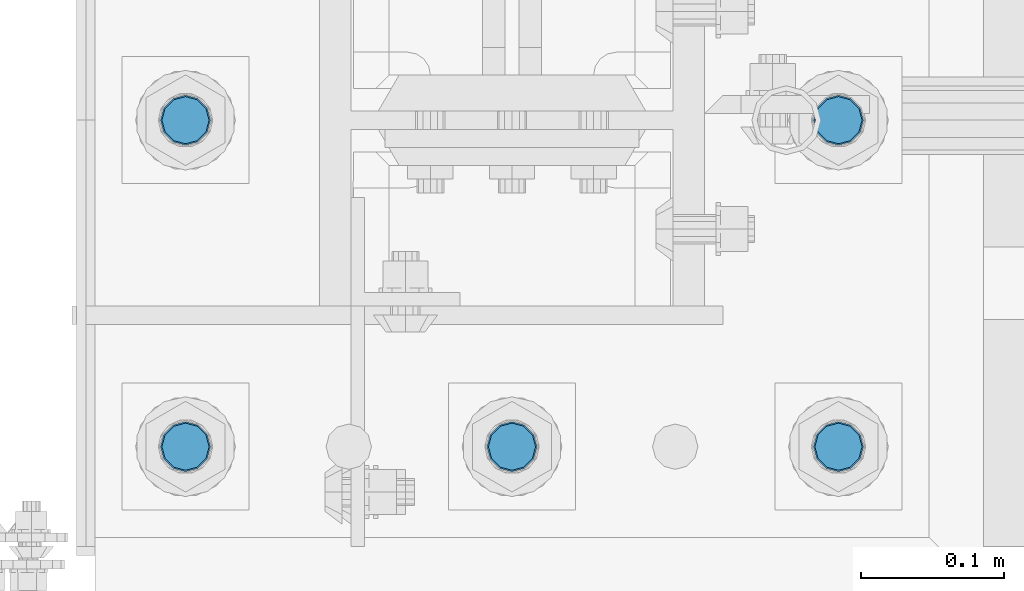
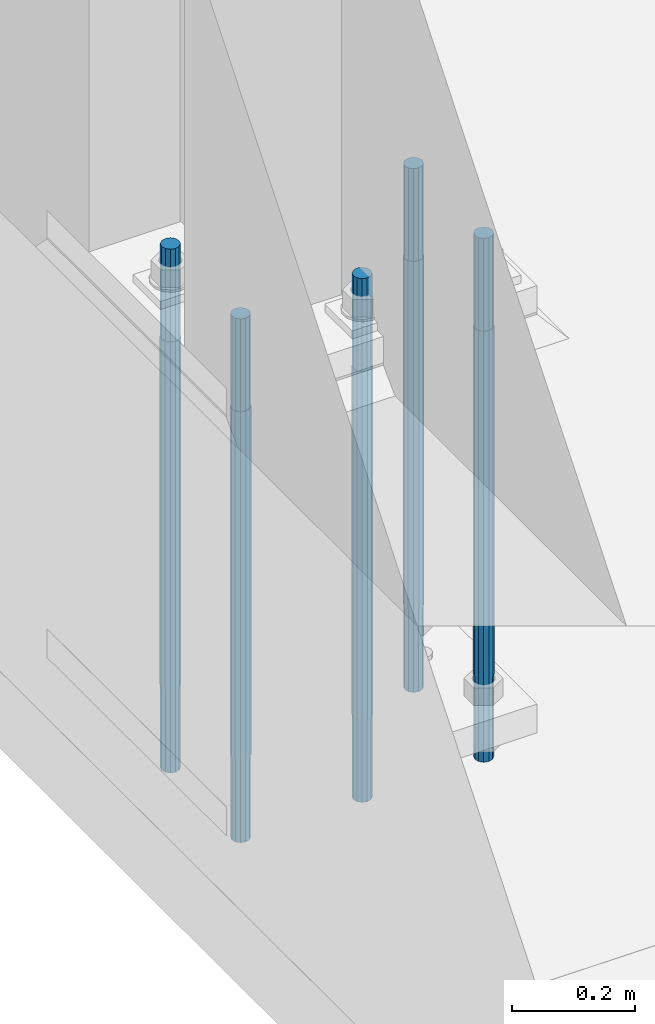
# One storey, part 558 of 1876: 5 columns, 1 element without a shape of its own.
"""IFC2X3 building model written with IfcOpenShell, lengths in millimetres."""

import ifcopenshell
import ifcopenshell.guid

model = None  # the IFC model being written
_history = None  # IfcOwnerHistory: only IFC2X3 demands one
_inside = {}  # id of a spatial element -> (the spatial element, [elements in it])
_under = {}  # id of a project, library or spatial element -> (it, [spatial elements below it])
_declared = {}  # id of a project -> (the project, [libraries it declares])
_typed = {}  # id of a type object -> (the type object, [elements of that type])
_made_of = {}  # id of a material, layer set ... -> (it, [elements and type objects made of it])


def new_model(schema):
    """Start an empty IFC model of exactly this schema.

    Asked for "IFC4X3", IfcOpenShell would pick the latest addendum, in which some entities
    have other attributes; the version numbers below select the first issue.
    IFC2X3 requires an IfcOwnerHistory on every rooted entity: one is made here for all.
    """
    global model, _history
    if schema == "IFC4X3":
        model = ifcopenshell.file(schema_version=(4, 3, 0, 0))
    else:
        model = ifcopenshell.file(schema=schema)
    _inside.clear()
    _under.clear()
    _declared.clear()
    _typed.clear()
    _made_of.clear()
    _history = None
    if model.schema == "IFC2X3":
        org = make("IfcOrganization", Name="unknown")
        user = make(
            "IfcPersonAndOrganization",
            ThePerson=make("IfcPerson", FamilyName="unknown"),
            TheOrganization=org,
        )
        app = make(
            "IfcApplication",
            ApplicationDeveloper=org,
            Version="unknown",
            ApplicationFullName="unknown",
            ApplicationIdentifier="unknown",
        )
        _history = make(
            "IfcOwnerHistory",
            OwningUser=user,
            OwningApplication=app,
            ChangeAction="ADDED",
            CreationDate=0,
        )
    return model


def make(cls, **values):
    """One entity of the class cls with the attributes given. An attribute that is None is left unset."""
    return model.create_entity(
        cls, **{name: value for name, value in values.items() if value is not None}
    )


def rooted(cls, **values):
    """An entity with a GlobalId (a new one), such as an element, a storey or a relation."""
    return make(cls, GlobalId=ifcopenshell.guid.new(), OwnerHistory=_history, **values)


def si_unit(unit_type, name, prefix=None):
    """IfcSIUnit, for example si_unit("LENGTHUNIT", "METRE", prefix="MILLI")."""
    return make("IfcSIUnit", UnitType=unit_type, Prefix=prefix, Name=name)


def assignment(units):
    """IfcUnitAssignment: the units of a project."""
    return None if units is None else make("IfcUnitAssignment", Units=units)


def point(xyz):
    """IfcCartesianPoint."""
    return None if xyz is None else make("IfcCartesianPoint", Coordinates=xyz)


def direction(xyz):
    """IfcDirection."""
    return None if xyz is None else make("IfcDirection", DirectionRatios=xyz)


def frame(location, z_axis=None, x_axis=None):
    """IfcAxis2Placement3D, a coordinate frame: its origin and axes. An axis left out is left unset."""
    return make(
        "IfcAxis2Placement3D",
        Location=point(location),
        Axis=direction(z_axis),
        RefDirection=direction(x_axis),
    )


def origin_with_axes():
    """The frame at (0, 0, 0) with the z axis (0, 0, 1) and the x axis (1, 0, 0) written out."""
    return frame((0.0, 0.0, 0.0), z_axis=(0.0, 0.0, 1.0), x_axis=(1.0, 0.0, 0.0))


def place(relative_to, where):
    """IfcLocalPlacement: puts the frame where relative to a parent placement (None: the world)."""
    return make(
        "IfcLocalPlacement", PlacementRelTo=relative_to, RelativePlacement=where
    )


def context(
    kind, dimensions, precision=None, world=None, true_north=None, identifier=None
):
    """IfcGeometricRepresentationContext, for example the 3D "Model" context."""
    return make(
        "IfcGeometricRepresentationContext",
        ContextIdentifier=identifier,
        ContextType=kind,
        CoordinateSpaceDimension=dimensions,
        Precision=precision,
        WorldCoordinateSystem=world,
        TrueNorth=true_north,
    )


def subcontext(parent, identifier, kind, view, scale=None):
    """IfcGeometricRepresentationSubContext, for example "Body" below "Model"."""
    return make(
        "IfcGeometricRepresentationSubContext",
        ContextIdentifier=identifier,
        ContextType=kind,
        ParentContext=parent,
        TargetScale=scale,
        TargetView=view,
    )


def project(units=None, contexts=None):
    """IfcProject with its units and contexts."""
    return rooted(
        "IfcProject",
        Name="project",
        RepresentationContexts=contexts,
        UnitsInContext=assignment(units),
    )


def spatial(cls, under=None, at=None, **own):
    """A site, building, storey or space (cls), placed at a placement, below another one or the project."""
    s = rooted(cls, ObjectPlacement=at, **own)
    if under is not None:
        _under.setdefault(under.id(), (under, []))[1].append(s)
    return s


def faces_of(points, faces, orient=None, outer=None):
    """IfcFace entities. A face is a list of loops; a loop is a list of indices into points, from 0.

    orient and outer hold one flag for each loop. By default every Orientation is true, the
    first loop of a face is its IfcFaceOuterBound and the others are IfcFaceBound.
    """
    made = []
    for i, loops in enumerate(faces):
        bounds = []
        for j, loop in enumerate(loops):
            is_outer = j == 0 if outer is None else outer[i][j]
            bounds.append(
                make(
                    "IfcFaceOuterBound" if is_outer else "IfcFaceBound",
                    Bound=make("IfcPolyLoop", Polygon=[points[k] for k in loop]),
                    Orientation=True if orient is None else orient[i][j],
                )
            )
        made.append(make("IfcFace", Bounds=bounds))
    return made


def faceted_brep(points, faces, orient=None, outer=None, voids=None):
    """IfcFacetedBrep: a solid bounded by flat faces; with voids (closed shells), ...WithVoids."""
    shared = [point(p) for p in points]
    hull = make("IfcClosedShell", CfsFaces=faces_of(shared, faces, orient, outer))
    if voids is None:
        return make("IfcFacetedBrep", Outer=hull)
    return make(
        "IfcFacetedBrepWithVoids",
        Outer=hull,
        Voids=[
            make(cls, CfsFaces=faces_of(shared, fs, o, b)) for cls, fs, o, b in voids
        ],
    )


def shape(context_of_items, identifier, shape_type, items):
    """IfcShapeRepresentation: the items that make up one representation, for example the "Body"."""
    return make(
        "IfcShapeRepresentation",
        ContextOfItems=context_of_items,
        RepresentationIdentifier=identifier,
        RepresentationType=shape_type,
        Items=items,
    )


def material(Name=None, Category=None):
    """IfcMaterial."""
    return make("IfcMaterial", Name=Name, Category=Category)


def made_of(thing, what):
    """Note that an element or type object is made of a material, layer set ...; save() writes the relation."""
    if what is not None:
        _made_of.setdefault(what.id(), (what, []))[1].append(thing)
    return thing


def type_object(cls, material=None, **own):
    """A type object (cls), such as IfcWallType, which elements share."""
    return made_of(rooted(cls, **own), material)


def element(
    cls,
    number,
    at=None,
    inside=None,
    cuts=None,
    type_object=None,
    material=None,
    context=None,
    identifier="Body",
    shape_type=None,
    held_by="IfcProductDefinitionShape",
    body=None,
    shapes=None,
    **own,
):
    """One element of the class cls, such as IfcWall. Its Tag is "e" and its number.

    at: its placement. inside: the storey or other place that contains it. cuts: it is an
    opening in that element (IfcRelVoidsElement). A single representation is given by context,
    identifier, shape_type and body (its items); several are given by shapes. held_by: the class
    of the entity that holds the representations. save() writes the other relations.
    """
    e = rooted(cls, Tag="e%d" % number, ObjectPlacement=at, **own)
    if body is not None:
        shapes = [shape(context, identifier, shape_type, body)]
    if shapes is not None:
        e.Representation = make(held_by, Representations=shapes)
    if inside is not None:
        _inside.setdefault(inside.id(), (inside, []))[1].append(e)
    if cuts is not None:
        rooted(
            "IfcRelVoidsElement", RelatingBuildingElement=cuts, RelatedOpeningElement=e
        )
    if type_object is not None:
        _typed.setdefault(type_object.id(), (type_object, []))[1].append(e)
    return made_of(e, material)


def aggregate(whole, parts):
    """IfcRelAggregates: a whole, such as a stair, and the parts it consists of."""
    return rooted("IfcRelAggregates", RelatingObject=whole, RelatedObjects=parts)


def save(model, path):
    """Write the relations noted so far, then the file.

    IfcRelAggregates (storeys below a building ...), IfcRelContainedInSpatialStructure (elements
    in a storey), IfcRelDefinesByType, IfcRelAssociatesMaterial and IfcRelDeclares: one each for
    every whole, place, type object, material and project.
    """
    for whole, parts in _under.values():
        aggregate(whole, parts)
    for where, things in _inside.values():
        rooted(
            "IfcRelContainedInSpatialStructure",
            RelatedElements=things,
            RelatingStructure=where,
        )
    for kind, things in _typed.values():
        rooted("IfcRelDefinesByType", RelatedObjects=things, RelatingType=kind)
    for what, things in _made_of.values():
        rooted("IfcRelAssociatesMaterial", RelatedObjects=things, RelatingMaterial=what)
    for by, libraries in _declared.values():
        rooted("IfcRelDeclares", RelatingContext=by, RelatedDefinitions=libraries)
    model.write(path)


model = new_model("IFC2X3")

# Units and contexts
model_context = context("Model", 3, precision=1e-05, world=origin_with_axes())
body_context = subcontext(model_context, "Body", "Model", "MODEL_VIEW")
ifc_project = project(units=[si_unit("LENGTHUNIT", "METRE", prefix="MILLI"), si_unit("AREAUNIT", "SQUARE_METRE"), si_unit("VOLUMEUNIT", "CUBIC_METRE"), si_unit("MASSUNIT", "GRAM", prefix="KILO"), si_unit("TIMEUNIT", "SECOND"), si_unit("PLANEANGLEUNIT", "RADIAN"), si_unit("SOLIDANGLEUNIT", "STERADIAN"), si_unit("THERMODYNAMICTEMPERATUREUNIT", "DEGREE_CELSIUS"), si_unit("LUMINOUSINTENSITYUNIT", "LUMEN")], contexts=[model_context])

# Site, building, storey
site_placement = place(None, origin_with_axes())
site = spatial("IfcSite", under=ifc_project, at=site_placement, CompositionType="ELEMENT")
building_placement = place(site_placement, origin_with_axes())
building = spatial("IfcBuilding", under=site, at=building_placement, Name="Undefined", CompositionType="ELEMENT")
storey_placement = place(building_placement, origin_with_axes())
storey = spatial("IfcBuildingStorey", under=building, at=storey_placement, Name="Undefined", CompositionType="ELEMENT", Elevation=0.0)

# Assembly, columns
assembly_placement = place(storey_placement, origin_with_axes())
assembly = element("IfcElementAssembly", 1, at=assembly_placement, inside=storey, Name="TEMPLATE", AssemblyPlace="NOTDEFINED", PredefinedType="RIGID_FRAME")
ifc_material = material(Name="STEEL/F1554-GR.105")
column_type = type_object("IfcColumnType", PredefinedType="NOTDEFINED")
column_1_placement = place(assembly_placement, frame((228.6, -7340.6, 0.0), z_axis=(1.0, 0.0, 0.0), x_axis=(0.0, 0.0, -1.0)))
column_1 = element("IfcColumn", 2, at=column_1_placement, type_object=column_type, material=ifc_material, Name="ANCHOR_BOLTS", context=body_context, shape_type="Brep", body=[
    faceted_brep([(-184.15, -14.2894191624437, 8.25), (-184.15, -8.25, 14.2894191624432), (-184.15, 0.0, 16.5), (-184.15, 8.25, 14.2894191624432), (-184.15, 14.2894191624437, 8.25), (-184.15, 16.5, 0.0), (-184.15, 14.2894191624437, -8.25), (-184.15, 8.25, -14.2894191624432), (-184.15, 0.0, -16.5), (-184.15, -8.25, -14.2894191624432), (-184.15, -14.2894191624437, -8.25), (-184.15, -16.5, 0.0), (0.0, 16.5, 0.0), (0.0, 14.2894191624437, -8.25), (0.0, 8.25, -14.2894191624432), (0.0, 0.0, -16.5), (0.0, -8.25, -14.2894191624432), (0.0, -14.2894191624437, -8.25), (0.0, -16.5, 0.0), (0.0, -14.2894191624437, 8.25), (0.0, -8.25, 14.2894191624432), (0.0, 0.0, 16.5), (0.0, 8.25, 14.2894191624432), (0.0, 14.2894191624437, 8.25), (0.0, -15.1229686135858, 8.73125000000073), (0.0, -8.73124999999999, 15.1229686135848), (0.0, 0.0, 17.4625000000015), (0.0, 8.73124999999999, 15.1229686135848), (0.0, 15.1229686135858, 8.73125000000073), (0.0, 17.4625, 0.0), (0.0, 15.1229686135858, -8.73125000000073), (0.0, 8.73124999999999, -15.1229686135848), (0.0, 0.0, -17.4625000000015), (0.0, -8.73124999999999, -15.1229686135848), (0.0, -15.1229686135857, -8.73125000000073), (0.0, -17.4625, 0.0), (692.15, -17.4624999999996, 0.0), (692.15, -15.1229686135857, 8.73124999999982), (692.15, -8.73124999999982, 15.1229686135857), (692.15, 0.0, 17.4624999999996), (692.15, 8.73124999999982, 15.1229686135857), (692.15, 15.1229686135857, 8.73124999999982), (692.15, 17.4624999999996, 0.0), (692.15, 15.1229686135857, -8.73124999999982), (692.15, 8.73124999999982, -15.1229686135857), (692.15, 0.0, -17.4624999999996), (692.15, -8.73124999999982, -15.1229686135857), (692.15, -15.1229686135857, -8.73124999999982), (692.15, -8.25, 14.2894191624437), (692.15, 0.0, 16.5), (692.15, 8.25, 14.2894191624437), (692.15, 14.2894191624437, 8.25), (692.15, 16.5, 0.0), (692.15, 14.2894191624437, -8.25), (692.15, 8.25, -14.2894191624437), (692.15, 0.0, -16.5), (692.15, -8.25, -14.2894191624437), (692.15, -14.2894191624437, -8.25), (692.15, -16.5, 0.0), (692.15, -14.2894191624437, 8.25), (857.25, -8.25, -14.2894191624437), (857.25, 0.0, -16.5), (857.25, 8.25, -14.2894191624437), (857.25, 14.2894191624437, -8.25), (857.25, 16.5, 0.0), (857.25, 14.2894191624437, 8.25), (857.25, 8.25, 14.2894191624437), (857.25, 0.0, 16.5), (857.25, -8.25, 14.2894191624437), (857.25, -14.2894191624437, 8.25), (857.25, -16.5, 0.0), (857.25, -14.2894191624437, -8.25)], [[[0, 1, 2, 3, 4, 5, 6, 7, 8, 9, 10, 11]], [[6, 5, 12, 13]], [[7, 6, 13, 14]], [[8, 7, 14, 15]], [[9, 8, 15, 16]], [[10, 9, 16, 17]], [[11, 10, 17, 18]], [[0, 11, 18, 19]], [[1, 0, 19, 20]], [[2, 1, 20, 21]], [[3, 2, 21, 22]], [[4, 3, 22, 23]], [[5, 4, 23, 12]], [[24, 25, 26, 27, 28, 29, 30, 31, 32, 33, 34, 35], [22, 21, 20, 19, 18, 17, 16, 15, 14, 13, 12, 23]], [[24, 35, 36, 37]], [[25, 24, 37, 38]], [[26, 25, 38, 39]], [[27, 26, 39, 40]], [[28, 27, 40, 41]], [[29, 28, 41, 42]], [[30, 29, 42, 43]], [[31, 30, 43, 44]], [[32, 31, 44, 45]], [[33, 32, 45, 46]], [[34, 33, 46, 47]], [[35, 34, 47, 36]], [[46, 45, 44, 43, 42, 41, 40, 39, 38, 37, 36, 47], [48, 49, 50, 51, 52, 53, 54, 55, 56, 57, 58, 59]], [[60, 61, 62, 63, 64, 65, 66, 67, 68, 69, 70, 71]], [[68, 67, 49, 48]], [[69, 68, 48, 59]], [[70, 69, 59, 58]], [[71, 70, 58, 57]], [[60, 71, 57, 56]], [[61, 60, 56, 55]], [[62, 61, 55, 54]], [[63, 62, 54, 53]], [[64, 63, 53, 52]], [[65, 64, 52, 51]], [[66, 65, 51, 50]], [[67, 66, 50, 49]]]),
])
column_2_placement = place(assembly_placement, frame((228.6, -7112.0, 0.0), z_axis=(1.0, 0.0, 0.0), x_axis=(0.0, 0.0, -1.0)))
column_2 = element("IfcColumn", 3, at=column_2_placement, type_object=column_type, material=ifc_material, Name="ANCHOR_BOLTS", context=body_context, shape_type="Brep", body=[
    faceted_brep([(-184.15, -14.2894191624437, 8.25), (-184.15, -8.25, 14.2894191624432), (-184.15, 0.0, 16.5), (-184.15, 8.25, 14.2894191624432), (-184.15, 14.2894191624437, 8.25), (-184.15, 16.5, 0.0), (-184.15, 14.2894191624437, -8.25), (-184.15, 8.25, -14.2894191624432), (-184.15, 0.0, -16.5), (-184.15, -8.25, -14.2894191624432), (-184.15, -14.2894191624437, -8.25), (-184.15, -16.5, 0.0), (0.0, 16.5, 0.0), (0.0, 14.2894191624437, -8.25), (0.0, 8.25, -14.2894191624432), (0.0, 0.0, -16.5), (0.0, -8.25, -14.2894191624432), (0.0, -14.2894191624437, -8.25), (0.0, -16.5, 0.0), (0.0, -14.2894191624437, 8.25), (0.0, -8.25, 14.2894191624432), (0.0, 0.0, 16.5), (0.0, 8.25, 14.2894191624432), (0.0, 14.2894191624437, 8.25), (0.0, -15.1229686135858, 8.73125000000073), (0.0, -8.73124999999999, 15.1229686135848), (0.0, 0.0, 17.4625000000015), (0.0, 8.73124999999999, 15.1229686135848), (0.0, 15.1229686135858, 8.73125000000073), (0.0, 17.4625, 0.0), (0.0, 15.1229686135858, -8.73125000000073), (0.0, 8.73124999999999, -15.1229686135848), (0.0, 0.0, -17.4625000000015), (0.0, -8.73124999999999, -15.1229686135848), (0.0, -15.1229686135857, -8.73125000000073), (0.0, -17.4625, 0.0), (692.15, -17.4624999999996, 0.0), (692.15, -15.1229686135857, 8.73124999999982), (692.15, -8.73124999999982, 15.1229686135857), (692.15, 0.0, 17.4624999999996), (692.15, 8.73124999999982, 15.1229686135857), (692.15, 15.1229686135857, 8.73124999999982), (692.15, 17.4624999999996, 0.0), (692.15, 15.1229686135857, -8.73124999999982), (692.15, 8.73124999999982, -15.1229686135857), (692.15, 0.0, -17.4624999999996), (692.15, -8.73124999999982, -15.1229686135857), (692.15, -15.1229686135857, -8.73124999999982), (692.15, -8.25, 14.2894191624437), (692.15, 0.0, 16.5), (692.15, 8.25, 14.2894191624437), (692.15, 14.2894191624437, 8.25), (692.15, 16.5, 0.0), (692.15, 14.2894191624437, -8.25), (692.15, 8.25, -14.2894191624437), (692.15, 0.0, -16.5), (692.15, -8.25, -14.2894191624437), (692.15, -14.2894191624437, -8.25), (692.15, -16.5, 0.0), (692.15, -14.2894191624437, 8.25), (857.25, -8.25, -14.2894191624437), (857.25, 0.0, -16.5), (857.25, 8.25, -14.2894191624437), (857.25, 14.2894191624437, -8.25), (857.25, 16.5, 0.0), (857.25, 14.2894191624437, 8.25), (857.25, 8.25, 14.2894191624437), (857.25, 0.0, 16.5), (857.25, -8.25, 14.2894191624437), (857.25, -14.2894191624437, 8.25), (857.25, -16.5, 0.0), (857.25, -14.2894191624437, -8.25)], [[[0, 1, 2, 3, 4, 5, 6, 7, 8, 9, 10, 11]], [[6, 5, 12, 13]], [[7, 6, 13, 14]], [[8, 7, 14, 15]], [[9, 8, 15, 16]], [[10, 9, 16, 17]], [[11, 10, 17, 18]], [[0, 11, 18, 19]], [[1, 0, 19, 20]], [[2, 1, 20, 21]], [[3, 2, 21, 22]], [[4, 3, 22, 23]], [[5, 4, 23, 12]], [[24, 25, 26, 27, 28, 29, 30, 31, 32, 33, 34, 35], [22, 21, 20, 19, 18, 17, 16, 15, 14, 13, 12, 23]], [[24, 35, 36, 37]], [[25, 24, 37, 38]], [[26, 25, 38, 39]], [[27, 26, 39, 40]], [[28, 27, 40, 41]], [[29, 28, 41, 42]], [[30, 29, 42, 43]], [[31, 30, 43, 44]], [[32, 31, 44, 45]], [[33, 32, 45, 46]], [[34, 33, 46, 47]], [[35, 34, 47, 36]], [[46, 45, 44, 43, 42, 41, 40, 39, 38, 37, 36, 47], [48, 49, 50, 51, 52, 53, 54, 55, 56, 57, 58, 59]], [[60, 61, 62, 63, 64, 65, 66, 67, 68, 69, 70, 71]], [[68, 67, 49, 48]], [[69, 68, 48, 59]], [[70, 69, 59, 58]], [[71, 70, 58, 57]], [[60, 71, 57, 56]], [[61, 60, 56, 55]], [[62, 61, 55, 54]], [[63, 62, 54, 53]], [[64, 63, 53, 52]], [[65, 64, 52, 51]], [[66, 65, 51, 50]], [[67, 66, 50, 49]]]),
])
column_3_placement = place(assembly_placement, frame((-1.13686837721616e-13, -7340.6, 0.0), z_axis=(1.0, 0.0, 0.0), x_axis=(0.0, 0.0, -1.0)))
column_3 = element("IfcColumn", 4, at=column_3_placement, type_object=column_type, material=ifc_material, Name="ANCHOR_BOLTS", context=body_context, shape_type="Brep", body=[
    faceted_brep([(-184.15, -14.2894191624437, 8.25), (-184.15, -8.25, 14.2894191624432), (-184.15, 0.0, 16.5), (-184.15, 8.25, 14.2894191624432), (-184.15, 14.2894191624437, 8.25), (-184.15, 16.5, 0.0), (-184.15, 14.2894191624437, -8.25), (-184.15, 8.25, -14.2894191624432), (-184.15, 0.0, -16.5), (-184.15, -8.25, -14.2894191624432), (-184.15, -14.2894191624437, -8.25), (-184.15, -16.5, 0.0), (0.0, 16.5, 0.0), (0.0, 14.2894191624437, -8.25), (0.0, 8.25, -14.2894191624432), (0.0, 0.0, -16.5), (0.0, -8.25, -14.2894191624432), (0.0, -14.2894191624437, -8.25), (0.0, -16.5, 0.0), (0.0, -14.2894191624437, 8.25), (0.0, -8.25, 14.2894191624432), (0.0, 0.0, 16.5), (0.0, 8.25, 14.2894191624432), (0.0, 14.2894191624437, 8.25), (0.0, -15.1229686135858, 8.73125000000073), (0.0, -8.73124999999999, 15.1229686135848), (0.0, 0.0, 17.4625000000015), (0.0, 8.73124999999999, 15.1229686135848), (0.0, 15.1229686135858, 8.73125000000073), (0.0, 17.4625, 0.0), (0.0, 15.1229686135858, -8.73125000000073), (0.0, 8.73124999999999, -15.1229686135848), (0.0, 0.0, -17.4625000000015), (0.0, -8.73124999999999, -15.1229686135848), (0.0, -15.1229686135857, -8.73125000000073), (0.0, -17.4625, 0.0), (692.15, -17.4624999999996, 0.0), (692.15, -15.1229686135857, 8.73124999999982), (692.15, -8.73124999999982, 15.1229686135857), (692.15, 0.0, 17.4624999999996), (692.15, 8.73124999999982, 15.1229686135857), (692.15, 15.1229686135857, 8.73124999999982), (692.15, 17.4624999999996, 0.0), (692.15, 15.1229686135857, -8.73124999999982), (692.15, 8.73124999999982, -15.1229686135857), (692.15, 0.0, -17.4624999999996), (692.15, -8.73124999999982, -15.1229686135857), (692.15, -15.1229686135857, -8.73124999999982), (692.15, -8.25, 14.2894191624437), (692.15, 0.0, 16.5), (692.15, 8.25, 14.2894191624437), (692.15, 14.2894191624437, 8.25), (692.15, 16.5, 0.0), (692.15, 14.2894191624437, -8.25), (692.15, 8.25, -14.2894191624437), (692.15, 0.0, -16.5), (692.15, -8.25, -14.2894191624437), (692.15, -14.2894191624437, -8.25), (692.15, -16.5, 0.0), (692.15, -14.2894191624437, 8.25), (857.25, -8.25, -14.2894191624437), (857.25, 0.0, -16.5), (857.25, 8.25, -14.2894191624437), (857.25, 14.2894191624437, -8.25), (857.25, 16.5, 0.0), (857.25, 14.2894191624437, 8.25), (857.25, 8.25, 14.2894191624437), (857.25, 0.0, 16.5), (857.25, -8.25, 14.2894191624437), (857.25, -14.2894191624437, 8.25), (857.25, -16.5, 0.0), (857.25, -14.2894191624437, -8.25)], [[[0, 1, 2, 3, 4, 5, 6, 7, 8, 9, 10, 11]], [[6, 5, 12, 13]], [[7, 6, 13, 14]], [[8, 7, 14, 15]], [[9, 8, 15, 16]], [[10, 9, 16, 17]], [[11, 10, 17, 18]], [[0, 11, 18, 19]], [[1, 0, 19, 20]], [[2, 1, 20, 21]], [[3, 2, 21, 22]], [[4, 3, 22, 23]], [[5, 4, 23, 12]], [[24, 25, 26, 27, 28, 29, 30, 31, 32, 33, 34, 35], [22, 21, 20, 19, 18, 17, 16, 15, 14, 13, 12, 23]], [[24, 35, 36, 37]], [[25, 24, 37, 38]], [[26, 25, 38, 39]], [[27, 26, 39, 40]], [[28, 27, 40, 41]], [[29, 28, 41, 42]], [[30, 29, 42, 43]], [[31, 30, 43, 44]], [[32, 31, 44, 45]], [[33, 32, 45, 46]], [[34, 33, 46, 47]], [[35, 34, 47, 36]], [[46, 45, 44, 43, 42, 41, 40, 39, 38, 37, 36, 47], [48, 49, 50, 51, 52, 53, 54, 55, 56, 57, 58, 59]], [[60, 61, 62, 63, 64, 65, 66, 67, 68, 69, 70, 71]], [[68, 67, 49, 48]], [[69, 68, 48, 59]], [[70, 69, 59, 58]], [[71, 70, 58, 57]], [[60, 71, 57, 56]], [[61, 60, 56, 55]], [[62, 61, 55, 54]], [[63, 62, 54, 53]], [[64, 63, 53, 52]], [[65, 64, 52, 51]], [[66, 65, 51, 50]], [[67, 66, 50, 49]]]),
])
column_4_placement = place(assembly_placement, frame((-228.6, -7340.6, 0.0), z_axis=(1.0, 0.0, 0.0), x_axis=(0.0, 0.0, -1.0)))
column_4 = element("IfcColumn", 5, at=column_4_placement, type_object=column_type, material=ifc_material, Name="ANCHOR_BOLTS", context=body_context, shape_type="Brep", body=[
    faceted_brep([(-184.15, -14.2894191624437, 8.25), (-184.15, -8.25, 14.2894191624432), (-184.15, 0.0, 16.5), (-184.15, 8.25, 14.2894191624432), (-184.15, 14.2894191624437, 8.25), (-184.15, 16.5, 0.0), (-184.15, 14.2894191624437, -8.25), (-184.15, 8.25, -14.2894191624432), (-184.15, 0.0, -16.5), (-184.15, -8.25, -14.2894191624432), (-184.15, -14.2894191624437, -8.25), (-184.15, -16.5, 0.0), (0.0, 16.5, 0.0), (0.0, 14.2894191624437, -8.25), (0.0, 8.25, -14.2894191624432), (0.0, 0.0, -16.5), (0.0, -8.25, -14.2894191624432), (0.0, -14.2894191624437, -8.25), (0.0, -16.5, 0.0), (0.0, -14.2894191624437, 8.25), (0.0, -8.25, 14.2894191624432), (0.0, 0.0, 16.5), (0.0, 8.25, 14.2894191624432), (0.0, 14.2894191624437, 8.25), (0.0, -15.1229686135858, 8.73125000000073), (0.0, -8.73124999999999, 15.1229686135848), (0.0, 0.0, 17.4625000000015), (0.0, 8.73124999999999, 15.1229686135848), (0.0, 15.1229686135858, 8.73125000000073), (0.0, 17.4625, 0.0), (0.0, 15.1229686135858, -8.73125000000073), (0.0, 8.73124999999999, -15.1229686135848), (0.0, 0.0, -17.4625000000015), (0.0, -8.73124999999999, -15.1229686135848), (0.0, -15.1229686135857, -8.73125000000073), (0.0, -17.4625, 0.0), (692.15, -17.4624999999996, 0.0), (692.15, -15.1229686135857, 8.73124999999982), (692.15, -8.73124999999982, 15.1229686135857), (692.15, 0.0, 17.4624999999996), (692.15, 8.73124999999982, 15.1229686135857), (692.15, 15.1229686135857, 8.73124999999982), (692.15, 17.4624999999996, 0.0), (692.15, 15.1229686135857, -8.73124999999982), (692.15, 8.73124999999982, -15.1229686135857), (692.15, 0.0, -17.4624999999996), (692.15, -8.73124999999982, -15.1229686135857), (692.15, -15.1229686135857, -8.73124999999982), (692.15, -8.25, 14.2894191624437), (692.15, 0.0, 16.5), (692.15, 8.25, 14.2894191624437), (692.15, 14.2894191624437, 8.25), (692.15, 16.5, 0.0), (692.15, 14.2894191624437, -8.25), (692.15, 8.25, -14.2894191624437), (692.15, 0.0, -16.5), (692.15, -8.25, -14.2894191624437), (692.15, -14.2894191624437, -8.25), (692.15, -16.5, 0.0), (692.15, -14.2894191624437, 8.25), (857.25, -8.25, -14.2894191624437), (857.25, 0.0, -16.5), (857.25, 8.25, -14.2894191624437), (857.25, 14.2894191624437, -8.25), (857.25, 16.5, 0.0), (857.25, 14.2894191624437, 8.25), (857.25, 8.25, 14.2894191624437), (857.25, 0.0, 16.5), (857.25, -8.25, 14.2894191624437), (857.25, -14.2894191624437, 8.25), (857.25, -16.5, 0.0), (857.25, -14.2894191624437, -8.25)], [[[0, 1, 2, 3, 4, 5, 6, 7, 8, 9, 10, 11]], [[6, 5, 12, 13]], [[7, 6, 13, 14]], [[8, 7, 14, 15]], [[9, 8, 15, 16]], [[10, 9, 16, 17]], [[11, 10, 17, 18]], [[0, 11, 18, 19]], [[1, 0, 19, 20]], [[2, 1, 20, 21]], [[3, 2, 21, 22]], [[4, 3, 22, 23]], [[5, 4, 23, 12]], [[24, 25, 26, 27, 28, 29, 30, 31, 32, 33, 34, 35], [22, 21, 20, 19, 18, 17, 16, 15, 14, 13, 12, 23]], [[24, 35, 36, 37]], [[25, 24, 37, 38]], [[26, 25, 38, 39]], [[27, 26, 39, 40]], [[28, 27, 40, 41]], [[29, 28, 41, 42]], [[30, 29, 42, 43]], [[31, 30, 43, 44]], [[32, 31, 44, 45]], [[33, 32, 45, 46]], [[34, 33, 46, 47]], [[35, 34, 47, 36]], [[46, 45, 44, 43, 42, 41, 40, 39, 38, 37, 36, 47], [48, 49, 50, 51, 52, 53, 54, 55, 56, 57, 58, 59]], [[60, 61, 62, 63, 64, 65, 66, 67, 68, 69, 70, 71]], [[68, 67, 49, 48]], [[69, 68, 48, 59]], [[70, 69, 59, 58]], [[71, 70, 58, 57]], [[60, 71, 57, 56]], [[61, 60, 56, 55]], [[62, 61, 55, 54]], [[63, 62, 54, 53]], [[64, 63, 53, 52]], [[65, 64, 52, 51]], [[66, 65, 51, 50]], [[67, 66, 50, 49]]]),
])
column_5_placement = place(assembly_placement, frame((-228.6, -7112.0, 0.0), z_axis=(1.0, 0.0, 0.0), x_axis=(0.0, 0.0, -1.0)))
column_5 = element("IfcColumn", 6, at=column_5_placement, type_object=column_type, material=ifc_material, Name="ANCHOR_BOLTS", context=body_context, shape_type="Brep", body=[
    faceted_brep([(-184.15, -14.2894191624437, 8.25), (-184.15, -8.25, 14.2894191624432), (-184.15, 0.0, 16.5), (-184.15, 8.25, 14.2894191624432), (-184.15, 14.2894191624437, 8.25), (-184.15, 16.5, 0.0), (-184.15, 14.2894191624437, -8.25), (-184.15, 8.25, -14.2894191624432), (-184.15, 0.0, -16.5), (-184.15, -8.25, -14.2894191624432), (-184.15, -14.2894191624437, -8.25), (-184.15, -16.5, 0.0), (0.0, 16.5, 0.0), (0.0, 14.2894191624437, -8.25), (0.0, 8.25, -14.2894191624432), (0.0, 0.0, -16.5), (0.0, -8.25, -14.2894191624432), (0.0, -14.2894191624437, -8.25), (0.0, -16.5, 0.0), (0.0, -14.2894191624437, 8.25), (0.0, -8.25, 14.2894191624432), (0.0, 0.0, 16.5), (0.0, 8.25, 14.2894191624432), (0.0, 14.2894191624437, 8.25), (0.0, -15.1229686135858, 8.73125000000073), (0.0, -8.73124999999999, 15.1229686135848), (0.0, 0.0, 17.4625000000015), (0.0, 8.73124999999999, 15.1229686135848), (0.0, 15.1229686135858, 8.73125000000073), (0.0, 17.4625, 0.0), (0.0, 15.1229686135858, -8.73125000000073), (0.0, 8.73124999999999, -15.1229686135848), (0.0, 0.0, -17.4625000000015), (0.0, -8.73124999999999, -15.1229686135848), (0.0, -15.1229686135857, -8.73125000000073), (0.0, -17.4625, 0.0), (692.15, -17.4624999999996, 0.0), (692.15, -15.1229686135857, 8.73124999999982), (692.15, -8.73124999999982, 15.1229686135857), (692.15, 0.0, 17.4624999999996), (692.15, 8.73124999999982, 15.1229686135857), (692.15, 15.1229686135857, 8.73124999999982), (692.15, 17.4624999999996, 0.0), (692.15, 15.1229686135857, -8.73124999999982), (692.15, 8.73124999999982, -15.1229686135857), (692.15, 0.0, -17.4624999999996), (692.15, -8.73124999999982, -15.1229686135857), (692.15, -15.1229686135857, -8.73124999999982), (692.15, -8.25, 14.2894191624437), (692.15, 0.0, 16.5), (692.15, 8.25, 14.2894191624437), (692.15, 14.2894191624437, 8.25), (692.15, 16.5, 0.0), (692.15, 14.2894191624437, -8.25), (692.15, 8.25, -14.2894191624437), (692.15, 0.0, -16.5), (692.15, -8.25, -14.2894191624437), (692.15, -14.2894191624437, -8.25), (692.15, -16.5, 0.0), (692.15, -14.2894191624437, 8.25), (857.25, -8.25, -14.2894191624437), (857.25, 0.0, -16.5), (857.25, 8.25, -14.2894191624437), (857.25, 14.2894191624437, -8.25), (857.25, 16.5, 0.0), (857.25, 14.2894191624437, 8.25), (857.25, 8.25, 14.2894191624437), (857.25, 0.0, 16.5), (857.25, -8.25, 14.2894191624437), (857.25, -14.2894191624437, 8.25), (857.25, -16.5, 0.0), (857.25, -14.2894191624437, -8.25)], [[[0, 1, 2, 3, 4, 5, 6, 7, 8, 9, 10, 11]], [[6, 5, 12, 13]], [[7, 6, 13, 14]], [[8, 7, 14, 15]], [[9, 8, 15, 16]], [[10, 9, 16, 17]], [[11, 10, 17, 18]], [[0, 11, 18, 19]], [[1, 0, 19, 20]], [[2, 1, 20, 21]], [[3, 2, 21, 22]], [[4, 3, 22, 23]], [[5, 4, 23, 12]], [[24, 25, 26, 27, 28, 29, 30, 31, 32, 33, 34, 35], [22, 21, 20, 19, 18, 17, 16, 15, 14, 13, 12, 23]], [[24, 35, 36, 37]], [[25, 24, 37, 38]], [[26, 25, 38, 39]], [[27, 26, 39, 40]], [[28, 27, 40, 41]], [[29, 28, 41, 42]], [[30, 29, 42, 43]], [[31, 30, 43, 44]], [[32, 31, 44, 45]], [[33, 32, 45, 46]], [[34, 33, 46, 47]], [[35, 34, 47, 36]], [[46, 45, 44, 43, 42, 41, 40, 39, 38, 37, 36, 47], [48, 49, 50, 51, 52, 53, 54, 55, 56, 57, 58, 59]], [[60, 61, 62, 63, 64, 65, 66, 67, 68, 69, 70, 71]], [[68, 67, 49, 48]], [[69, 68, 48, 59]], [[70, 69, 59, 58]], [[71, 70, 58, 57]], [[60, 71, 57, 56]], [[61, 60, 56, 55]], [[62, 61, 55, 54]], [[63, 62, 54, 53]], [[64, 63, 53, 52]], [[65, 64, 52, 51]], [[66, 65, 51, 50]], [[67, 66, 50, 49]]]),
])
aggregate(assembly, [column_1, column_2, column_3, column_4, column_5])

save(model, "model.ifc")
